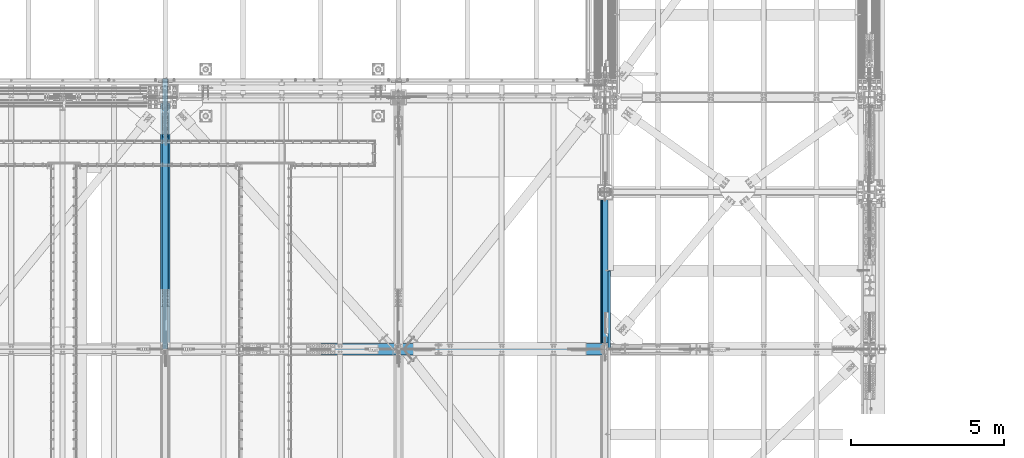
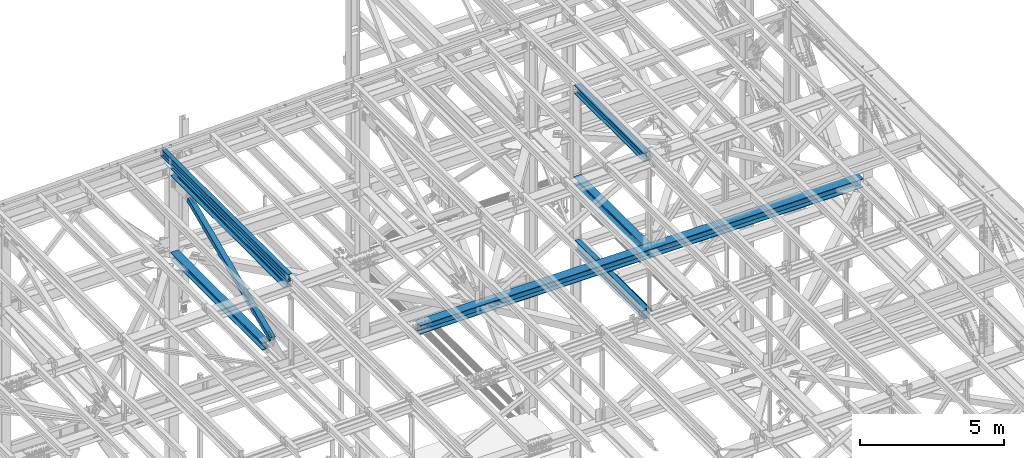
# One storey, part 1926 of 3843: 8 beams, 1 member, 9 elements without a shape of their own.
"""IFC2X3 building model written with IfcOpenShell, lengths in millimetres."""

from ifc_helpers import new_model, si_unit, frame, origin_with_axes, place, context, subcontext, project, spatial, faceted_brep, material, type_object, element, aggregate, save


model = new_model("IFC2X3")

# Units and contexts
model_context = context("Model", 3, precision=1e-05, world=origin_with_axes())
body_context = subcontext(model_context, "Body", "Model", "MODEL_VIEW")
ifc_project = project(units=[si_unit("LENGTHUNIT", "METRE", prefix="MILLI"), si_unit("AREAUNIT", "SQUARE_METRE"), si_unit("VOLUMEUNIT", "CUBIC_METRE"), si_unit("MASSUNIT", "GRAM", prefix="KILO"), si_unit("TIMEUNIT", "SECOND"), si_unit("PLANEANGLEUNIT", "RADIAN"), si_unit("SOLIDANGLEUNIT", "STERADIAN"), si_unit("THERMODYNAMICTEMPERATUREUNIT", "DEGREE_CELSIUS"), si_unit("LUMINOUSINTENSITYUNIT", "LUMEN")], contexts=[model_context])

# Site, building, storey
site_placement = place(None, origin_with_axes())
site = spatial("IfcSite", under=ifc_project, at=site_placement, CompositionType="ELEMENT")
building_placement = place(site_placement, origin_with_axes())
building = spatial("IfcBuilding", under=site, at=building_placement, Name="Undefined", CompositionType="ELEMENT")
storey_placement = place(building_placement, origin_with_axes())
storey = spatial("IfcBuildingStorey", under=building, at=storey_placement, Name="Undefined", CompositionType="ELEMENT", Elevation=0.0)

# Assembly, beam
assembly_1_placement = place(storey_placement, origin_with_axes())
assembly_1 = element("IfcElementAssembly", 1, at=assembly_1_placement, inside=storey, Name="BEAM", AssemblyPlace="NOTDEFINED", PredefinedType="RIGID_FRAME")
ifc_material_1 = material(Name="STEEL/A992")
beam_type_1 = type_object("IfcBeamType", Name="W12X26", PredefinedType="NOTDEFINED")
beam_1_placement = place(assembly_1_placement, frame((62633.1092623524, 83985.3212537026, 46137.8441766796), z_axis=(-0.0211520984080562, 0.00142216699976416, 0.999775257832459), x_axis=(0.0, 0.999998988266278, -0.00142248600037892)))
beam_1 = element("IfcBeam", 2, at=beam_1_placement, type_object=beam_type_1, material=ifc_material_1, Name="BEAM", ObjectType="W12X26", context=body_context, shape_type="Brep", body=[
    faceted_brep([(12.7024967079196, 82.5500000003085, -155.575000000172), (12.6889505463769, 82.5500000002867, -146.050000000156), (8839.20894275262, 82.5499999999811, -146.049999986019), (8839.20894275268, 82.5500000000102, -155.574999986035), (12.686562263887, 3.17500000043219, -146.050000000236), (8839.20894275226, 3.1750000001266, -146.049999986106), (12.2711466436303, 3.1749999995809, 146.050000000294), (8839.20894275064, 3.17499999927531, 146.050000014417), (12.2735349261202, 82.5499999994281, 146.050000000381), (8839.20894275102, 82.5499999991225, 146.050000014511), (12.2599887646065, 82.5499999994063, 155.57500000039), (8839.20894275096, 82.5499999991007, 155.575000014534), (12.2550211370108, -82.5500000002867, 155.575000000208), (8839.20894275019, -82.550000000585, 155.575000014338), (12.268567298539, -82.5500000002503, 146.050000000192), (8839.20894275024, -82.5500000005559, 146.050000014322), (12.2709555810434, -3.17500000040309, 146.050000000272), (8839.20894275061, -3.17500000070868, 146.050000014409), (12.686371201271, -3.1749999995518, -146.050000000243), (8839.20894275223, -3.17499999985012, -146.049999986106), (12.6839829187811, -82.5499999994063, -146.050000000345), (8839.20894275187, -82.5499999997046, -146.0499999862), (12.6975290803239, -82.5499999993772, -155.575000000354), (8839.20894275189, -82.5499999996828, -155.574999986224)], [[[0, 1, 2, 3]], [[1, 4, 5, 2]], [[4, 6, 7, 5]], [[6, 8, 9, 7]], [[8, 10, 11, 9]], [[10, 12, 13, 11]], [[12, 14, 15, 13]], [[14, 16, 17, 15]], [[16, 18, 19, 17]], [[18, 20, 21, 19]], [[20, 22, 23, 21]], [[22, 0, 3, 23]], [[5, 7, 9, 11, 13, 15, 17, 19, 21, 23, 3, 2]], [[22, 20, 18, 16, 14, 12, 10, 8, 6, 4, 1, 0]]]),
])
aggregate(assembly_1, [beam_1])

assembly_2_placement = place(storey_placement, origin_with_axes())
assembly_2 = element("IfcElementAssembly", 3, at=assembly_2_placement, inside=storey, Name="BENT_PLATE", AssemblyPlace="NOTDEFINED", PredefinedType="RIGID_FRAME")
ifc_material_2 = material(Name="STEEL/A36")
beam_type_2 = type_object("IfcBeamType", PredefinedType="NOTDEFINED")
beam_2_placement = place(assembly_2_placement, frame((77179.4875000005, 85277.325, 39627.1749999995), z_axis=(0.0, 1.0, 0.0), x_axis=(-1.0, 0.0, 0.0)))
beam_2 = element("IfcBeam", 4, at=beam_2_placement, type_object=beam_type_2, material=ifc_material_2, Name="BENT_PLATE", context=body_context, shape_type="Brep", body=[
    faceted_brep([(73.0250000002416, -7.27595761418343e-12, 1273.17500000002), (69.8500000002678, 3.17500000000291, 1270.00000000003), (0.0, 3.17500000000291, 1270.00000000003), (0.0, -7.27595761418343e-12, 1273.175), (73.0250000004453, 73.0249999997468, 1273.175), (69.8500000003405, 73.0249999997541, 1270.00000000003), (76.200000000259, -3.17500000000291, -1273.175), (0.0, -3.17500000000291, -1273.175), (0.0, 3.17500000000291, -1273.175), (69.8500000002678, 3.17500000000291, -1273.175), (69.8500000003405, 73.0249999997541, -1273.175), (76.2000000003463, 73.0249999997395, -1273.175), (76.200000000259, -3.17500000000291, 1273.175), (76.2000000003463, 73.0249999997395, 1273.175), (0.0, -3.17500000000291, 1273.175)], [[[0, 1, 2, 3]], [[4, 5, 1, 0]], [[6, 7, 8, 9, 10, 11]], [[12, 6, 11, 13]], [[14, 7, 6, 12]], [[8, 7, 14, 3, 2]], [[9, 8, 2, 1]], [[10, 9, 1, 5]], [[13, 11, 10, 5, 4]], [[14, 12, 13, 4, 0, 3]]]),
])
aggregate(assembly_2, [beam_2])

assembly_3_placement = place(storey_placement, origin_with_axes())
assembly_3 = element("IfcElementAssembly", 5, at=assembly_3_placement, inside=storey, Name="BEAM", AssemblyPlace="NOTDEFINED", PredefinedType="RIGID_FRAME")
beam_type_3 = type_object("IfcBeamType", Name="W12X79", PredefinedType="NOTDEFINED")
beam_3_placement = place(assembly_3_placement, frame((62636.399999016, 85661.4999999939, 42256.5692801511), z_axis=(0.0, 0.001528912000329, 0.999998831213365), x_axis=(0.0, 0.999998831213365, -0.00152891200032518)))
beam_3 = element("IfcBeam", 6, at=beam_3_placement, type_object=beam_type_3, material=ifc_material_1, Name="BEAM", ObjectType="W12X79", context=body_context, shape_type="Brep", body=[
    faceted_brep([(6.34999999578577, -153.987500000003, -138.11249999961), (6.34999999578577, -153.987500000003, -157.162499999562), (6362.46714881413, -153.987500000003, -157.162499986967), (6362.46714881428, -153.987500000003, -138.112499986986), (6.34999999578577, -6.34999999999854, -138.11249999961), (6362.46714881428, -6.34999999999854, -138.112499986986), (6.34999999578577, -6.34999999999854, 138.112499999675), (6362.4671488163, -6.34999999999854, 138.112500012634), (6.34999999578577, -153.987500000003, 138.112499999675), (6362.4671488163, -153.987500000003, 138.112500012634), (6.34999999578577, -153.987500000003, 157.162499999627), (6362.46714881643, -153.987500000003, 157.162500012608), (6.34999999578577, 153.987500000003, 157.162499999627), (6362.46714881643, 153.987500000003, 157.162500012608), (6.34999999578577, 153.987500000003, 138.112499999675), (6362.4671488163, 153.987500000003, 138.112500012634), (6.34999999578577, 6.34999999999854, 138.112499999675), (6362.4671488163, 6.34999999999854, 138.112500012634), (6.34999999578577, 6.34999999999854, -138.11249999961), (6362.46714881428, 6.34999999999854, -138.112499986986), (6.34999999578577, 153.987500000003, -138.11249999961), (6362.46714881428, 153.987500000003, -138.112499986986), (6.34999999578577, 153.987500000003, -157.162499999562), (6362.46714881413, 153.987500000003, -157.162499986967)], [[[0, 1, 2, 3]], [[4, 0, 3, 5]], [[6, 4, 5, 7]], [[8, 6, 7, 9]], [[10, 8, 9, 11]], [[12, 10, 11, 13]], [[14, 12, 13, 15]], [[16, 14, 15, 17]], [[18, 16, 17, 19]], [[20, 18, 19, 21]], [[1, 0, 4, 6, 8, 10, 12, 14, 16, 18, 20, 22]], [[1, 22, 23, 2]], [[19, 17, 15, 13, 11, 9, 7, 5, 3, 2, 23, 21]], [[22, 20, 21, 23]]]),
])
aggregate(assembly_3, [beam_3])

assembly_4_placement = place(storey_placement, origin_with_axes())
assembly_4 = element("IfcElementAssembly", 7, at=assembly_4_placement, inside=storey, Name="BEAM", AssemblyPlace="NOTDEFINED", PredefinedType="RIGID_FRAME")
beam_type_4 = type_object("IfcBeamType", Name="W14X120", PredefinedType="NOTDEFINED")
beam_4_placement = place(assembly_4_placement, frame((67716.4, 83985.1, 42261.5850587552), z_axis=(-0.00048281500021403, 0.0, 0.999999883444831), x_axis=(0.999999883444831, 0.0, 0.000482815000217081)))
beam_4 = element("IfcBeam", 8, at=beam_4_placement, type_object=beam_type_4, material=ifc_material_1, Name="BEAM", ObjectType="W14X120", context=body_context, shape_type="Brep", body=[
    faceted_brep([(6.34999999732827, -185.737500000003, -184.1500000003), (6.35000000674336, -185.737500000003, -160.33750000099), (6.34999999732827, -7.14375000000291, -160.337500000271), (6.34999999732827, -7.14375000000291, 160.337500000249), (6.35000000639411, -185.737500000003, 160.337500001014), (6.34999999734282, -185.737500000003, 184.150000000292), (6.34999999734282, 185.737500000003, 184.150000000292), (6.35000000639411, 185.737500000003, 160.337500001014), (6.34999999732827, 7.14375000000291, 160.337500000249), (6.34999999732827, 7.14375000000291, -160.337500000271), (6.35000000674336, 185.737500000003, -160.33750000099), (6.34999999732827, 185.737500000003, -184.1500000003), (17732.2881540681, -185.737500000003, -184.150000045403), (17732.2996511016, -185.737500000003, -160.337500045367), (17732.299651277, -147.637402224384, -160.337499988658), (17732.2996511016, -7.14375000000291, -160.337500045367), (17732.4544778199, -7.14375000000291, 160.337499955145), (17732.4544776769, -147.637402224384, 160.337500011701), (17732.4544778199, -185.737500000003, 160.337499955145), (17732.4659748534, -185.737500000003, 184.149999955182), (17732.4659746868, -147.637402224384, 184.15000001173), (17732.4659746868, 147.637584881566, 184.15000001173), (17732.4659748534, 185.737500000003, 184.149999955182), (17732.4544778199, 185.737500000003, 160.337499955145), (17732.4544776769, 147.637584881566, 160.337500011701), (17732.4544778199, 7.14375000000291, 160.337499955145), (17732.4356630119, 7.14375000000291, 121.368524726146), (17732.3184451861, 7.14375000000291, -121.411446977356), (17732.2996511016, 7.14375000000291, -160.337500045367), (17732.299651277, 147.637584881566, -160.337499988658), (17732.2996511016, 185.737500000003, -160.337500045367), (17732.2881540681, 185.737500000003, -184.150000045403), (17732.2881542671, -147.637402224384, -184.149999988687), (17732.2881542671, 147.637584881566, -184.149999988687)], [[[0, 1, 2, 3, 4, 5, 6, 7, 8, 9, 10, 11]], [[1, 0, 12, 13]], [[2, 1, 13, 14, 15]], [[3, 2, 15, 16]], [[4, 3, 16, 17, 18]], [[5, 4, 18, 19]], [[6, 5, 19, 20, 21, 22]], [[7, 6, 22, 23]], [[8, 7, 23, 24, 25]], [[9, 8, 25, 26, 27, 28]], [[10, 9, 28, 29, 30]], [[11, 10, 30, 31]], [[29, 28, 27, 26, 25, 24, 23, 22, 21, 20, 19, 18, 17, 16, 15, 14, 13, 12, 32, 33, 31, 30]], [[0, 11, 31, 33, 32, 12]]]),
])
aggregate(assembly_4, [beam_4])

# Assembly, member
assembly_5_placement = place(storey_placement, origin_with_axes())
assembly_5 = element("IfcElementAssembly", 9, at=assembly_5_placement, inside=storey, AssemblyPlace="NOTDEFINED", PredefinedType="RIGID_FRAME")
ifc_material_3 = material()
member_type = type_object("IfcMemberType", Name="HSS8X8X1/2", PredefinedType="NOTDEFINED")
member_placement = place(assembly_5_placement, frame((62636.3999983394, 83985.0999999778, 42259.1323511586), z_axis=(1.0, 0.0, 0.0), x_axis=(0.0, 0.919173162811554, 0.393853648919246)))
member = element("IfcMember", 10, at=member_placement, type_object=member_type, material=ifc_material_3, ObjectType="HSS8X8X1/2", context=body_context, shape_type="Brep", body=[
    faceted_brep([(1364.28375243548, -101.599999994409, 17.4625000000015), (1364.28375243559, -88.8999999944626, 17.4625000000015), (1616.69625280701, -88.8999999935022, 17.4625000000015), (1616.69625280688, -101.599999993456, 17.4625000000015), (1623.37886209866, -88.8999999934804, 16.1332463655199), (1623.37886209856, -101.599999993434, 16.1332463655199), (1629.04410470369, -88.8999999934658, 12.3478522782025), (1629.04410470356, -101.599999993405, 12.3478522782025), (1632.82949879098, -88.899999993444, 6.68260967316746), (1632.82949879084, -101.59999999339, 6.68260967316746), (1616.69625280688, -101.599999993456, -17.4625000000015), (1616.69625280701, -88.8999999935022, -17.4625000000015), (1364.28375243559, -88.8999999944626, -17.4625000000015), (1364.28375243548, -101.599999994409, -17.4625000000015), (1623.37886209856, -101.599999993434, -16.1332463655199), (1623.37886209866, -88.8999999934804, -16.1332463655199), (1629.04410470356, -101.599999993405, -12.3478522782025), (1629.04410470369, -88.8999999934658, -12.3478522782025), (1632.82949879084, -101.59999999339, -6.68260967316746), (1632.82949879098, -88.899999993444, -6.68260967316746), (1634.15875242533, -101.599999993383, 3.81471181754023e-07), (1634.15875242547, -88.899999993444, 3.81471181754023e-07), (1364.28375243676, 88.9000000047981, 17.4625000000015), (1364.28375243685, 101.600000004752, 17.4625000000015), (1616.69625280882, 101.600000005705, 17.4625000000015), (1616.69625280872, 88.9000000057513, 17.4625000000015), (1623.37886210049, 101.600000005719, 16.1332463655199), (1623.37886210038, 88.9000000057804, 16.1332463655199), (1629.04410470549, 101.600000005748, 12.3478522782025), (1629.04410470539, 88.9000000057949, 12.3478522782025), (1632.82949879281, 101.600000005763, 6.68260967316746), (1632.82949879269, 88.9000000058168, 6.68260967316746), (1616.69625280872, 88.9000000057513, -17.4625000000015), (1616.69625280882, 101.600000005705, -17.4625000000015), (1364.28375243685, 101.600000004752, -17.4625000000015), (1364.28375243676, 88.9000000047981, -17.4625000000015), (1623.37886210038, 88.9000000057804, -16.1332463655199), (1623.37886210049, 101.600000005719, -16.1332463655199), (1629.04410470539, 88.9000000057949, -12.3478522782025), (1629.04410470549, 101.600000005748, -12.3478522782025), (1632.82949879269, 88.9000000058168, -6.68260967316746), (1632.82949879281, 101.600000005763, -6.68260967316746), (1634.15875242716, 88.900000005824, 3.81471181754023e-07), (1634.15875242728, 101.600000005777, 3.81471181754023e-07), (1364.28375243559, -88.8999999944626, 88.9000000000015), (1364.28375243676, 88.9000000047981, 88.9000000000015), (7586.19055475817, 88.9000000283941, 88.9000000000015), (7586.19055475698, -88.8999999708667, 88.9000000000015), (1364.28375243685, 101.600000004752, 101.599999999999), (7586.19055475826, 101.60000002834, 101.599999999999), (7586.19055475826, 101.60000002834, 41.2750000000015), (7333.77805439882, 101.600000027387, 41.2750000000015), (7327.09544510716, 101.600000027358, 39.9457463655199), (7321.43020250213, 101.600000027336, 36.1603522782025), (7317.64480841484, 101.600000027322, 30.4951096731675), (7316.31555478036, 101.600000027314, 23.8125003814712), (7317.64480841484, 101.600000027322, 17.1298903268325), (7321.43020250213, 101.600000027336, 11.4646477217975), (7327.09544510716, 101.600000027358, 7.67925363448012), (7333.77805439882, 101.600000027387, 6.34999999999854), (7586.19055475826, 101.60000002834, 6.34999999999854), (7586.19055475826, 101.60000002834, -101.599999999999), (1364.28375243685, 101.600000004752, -101.599999999999), (7586.19055475817, 88.9000000283941, 41.2750000000015), (7333.7780543987, 88.9000000274264, 41.2750000000015), (7327.09544510703, 88.9000000274118, 39.9457463655199), (7321.43020250202, 88.9000000273973, 36.1603522782025), (7317.64480841473, 88.9000000273754, 30.4951096731675), (7316.31555478023, 88.9000000273754, 23.8125003814712), (7317.64480841473, 88.9000000273754, 17.1298903268325), (7321.43020250202, 88.9000000273973, 11.4646477217975), (7327.09544510703, 88.9000000274118, 7.67925363448012), (7333.7780543987, 88.9000000274264, 6.34999999999854), (7586.19055475817, 88.9000000283941, 6.34999999999854), (1364.28375243676, 88.9000000047981, -88.9000000000015), (1364.28375243559, -88.8999999944626, -88.9000000000015), (7586.19055475698, -88.8999999708667, -88.9000000000015), (7586.19055475817, 88.9000000283941, -88.9000000000015), (7327.09544510521, -101.599999971795, 39.9457463655199), (7327.09544510533, -88.8999999718562, 39.9457463655199), (7333.77805439699, -88.8999999718271, 41.2750000000015), (7333.77805439687, -101.599999971773, 41.2750000000015), (7321.43020250018, -101.599999971817, 36.1603522782025), (7321.43020250033, -88.8999999718708, 36.1603522782025), (7317.64480841289, -101.599999971839, 30.4951096731675), (7317.64480841301, -88.8999999718853, 30.4951096731675), (7316.31555477841, -101.599999971846, 23.8125003814712), (7316.31555477851, -88.8999999718926, 23.8125003814712), (7317.64480841289, -101.599999971839, 17.1298903268325), (7317.64480841301, -88.8999999718853, 17.1298903268325), (7321.43020250018, -101.599999971817, 11.4646477217975), (7321.43020250033, -88.8999999718708, 11.4646477217975), (7327.09544510521, -101.599999971795, 7.67925363448012), (7327.09544510533, -88.8999999718562, 7.67925363448012), (7333.77805439687, -101.599999971773, 6.34999999999854), (7333.77805439699, -88.8999999718271, 6.34999999999854), (7586.1905547569, -101.599999970813, 6.34999999999854), (7586.19055475698, -88.8999999708667, 6.34999999999854), (7586.1905547569, -101.599999970813, -101.599999999999), (1364.28375243548, -101.599999994409, -101.599999999999), (7586.19055475698, -88.8999999708667, 41.2750000000015), (7586.1905547569, -101.599999970813, 41.2750000000015), (7586.1905547569, -101.599999970813, 101.599999999999), (1364.28375243548, -101.599999994409, 101.599999999999)], [[[0, 1, 2, 3]], [[3, 2, 4, 5]], [[5, 4, 6, 7]], [[7, 6, 8, 9]], [[10, 11, 12, 13]], [[14, 15, 11, 10]], [[16, 17, 15, 14]], [[18, 19, 17, 16]], [[20, 21, 19, 18]], [[9, 8, 21, 20]], [[22, 23, 24, 25]], [[25, 24, 26, 27]], [[27, 26, 28, 29]], [[29, 28, 30, 31]], [[32, 33, 34, 35]], [[36, 37, 33, 32]], [[38, 39, 37, 36]], [[40, 41, 39, 38]], [[42, 43, 41, 40]], [[31, 30, 43, 42]], [[44, 45, 46, 47]], [[28, 26, 24, 23, 48, 49, 50, 51, 52, 53, 54, 55, 56, 57, 58, 59, 60, 61, 62, 34, 33, 37, 39, 41, 43, 30]], [[63, 64, 51, 50]], [[65, 52, 51, 64]], [[66, 53, 52, 65]], [[67, 54, 53, 66]], [[68, 55, 54, 67]], [[69, 56, 55, 68]], [[70, 57, 56, 69]], [[71, 58, 57, 70]], [[72, 59, 58, 71]], [[73, 60, 59, 72]], [[74, 75, 76, 77]], [[78, 79, 80, 81]], [[82, 83, 79, 78]], [[84, 85, 83, 82]], [[86, 87, 85, 84]], [[88, 89, 87, 86]], [[90, 91, 89, 88]], [[92, 93, 91, 90]], [[94, 95, 93, 92]], [[96, 97, 95, 94]], [[98, 61, 60, 73, 77, 76, 97, 96]], [[99, 62, 61, 98]], [[75, 74, 35, 34, 62, 99, 13, 12]], [[6, 4, 2, 1, 44, 47, 100, 80, 79, 83, 85, 87, 89, 91, 93, 95, 97, 76, 75, 12, 11, 15, 17, 19, 21, 8]], [[101, 81, 80, 100]], [[47, 46, 63, 50, 49, 102, 101, 100]], [[48, 103, 102, 49]], [[16, 14, 10, 13, 99, 98, 96, 94, 92, 90, 88, 86, 84, 82, 78, 81, 101, 102, 103, 0, 3, 5, 7, 9, 20, 18]], [[103, 48, 23, 22, 45, 44, 1, 0]], [[38, 36, 32, 35, 74, 77, 73, 72, 71, 70, 69, 68, 67, 66, 65, 64, 63, 46, 45, 22, 25, 27, 29, 31, 42, 40]]]),
])
aggregate(assembly_5, [member])

# Assembly, beam
assembly_6_placement = place(storey_placement, origin_with_axes())
assembly_6 = element("IfcElementAssembly", 11, at=assembly_6_placement, inside=storey, Name="BEAM", AssemblyPlace="NOTDEFINED", PredefinedType="RIGID_FRAME")
beam_type_5 = type_object("IfcBeamType", Name="W14X68", PredefinedType="NOTDEFINED")
beam_5_placement = place(assembly_6_placement, frame((77012.8, 83985.1, 46096.5034722281), z_axis=(0.0, 0.00380209400005697, 0.999992772014486), x_axis=(0.0, 0.999992772014486, -0.00380209400005526)))
beam_5 = element("IfcBeam", 12, at=beam_5_placement, type_object=beam_type_5, material=ifc_material_1, Name="BEAM", ObjectType="W14X68", context=body_context, shape_type="Brep", body=[
    faceted_brep([(213.330124371947, -127.0, -158.749999999149), (213.402554786167, -127.0, -177.799999999123), (5017.21227670657, -127.0, -177.799999986091), (5017.13984629234, -127.0, -158.749999986125), (213.330124371947, -5.55624999999418, -158.749999999149), (5017.13984629234, -5.55624999999418, -158.749999986125), (212.12295080148, -5.55624999999418, 158.750000000298), (5015.93267272189, -5.55624999999418, 158.75000001333), (212.12295080148, -127.0, 158.750000000298), (5015.93267272189, -127.0, 158.75000001333), (212.050520387245, -127.0, 177.800000000265), (5015.86024230765, -127.0, 177.800000013296), (212.050520387245, 127.0, 177.800000000265), (5015.86024230765, 127.0, 177.800000013296), (212.12295080148, 127.0, 158.750000000298), (5015.93267272189, 127.0, 158.75000001333), (212.12295080148, 5.55624999999418, 158.750000000298), (5015.93267272189, 5.55624999999418, 158.75000001333), (213.330124371947, 5.55624999999418, -158.749999999149), (5016.00164596931, 5.55624999999418, 140.609273114424), (5016.92471835065, 5.55624999999418, -102.168972073261), (5017.13984629234, 5.55624999999418, -158.749999986125), (213.330124371947, 127.0, -158.749999999149), (5017.13984629234, 127.0, -158.749999986125), (213.402554786167, 127.0, -177.799999999123), (5017.21227670657, 127.0, -177.799999986091)], [[[0, 1, 2, 3]], [[4, 0, 3, 5]], [[6, 4, 5, 7]], [[8, 6, 7, 9]], [[10, 8, 9, 11]], [[12, 10, 11, 13]], [[14, 12, 13, 15]], [[16, 14, 15, 17]], [[18, 16, 17, 19, 20, 21]], [[22, 18, 21, 23]], [[1, 0, 4, 6, 8, 10, 12, 14, 16, 18, 22, 24]], [[1, 24, 25, 2]], [[21, 20, 19, 17, 15, 13, 11, 9, 7, 5, 3, 2, 25, 23]], [[24, 22, 23, 25]]]),
])
aggregate(assembly_6, [beam_5])

assembly_7_placement = place(storey_placement, origin_with_axes())
assembly_7 = element("IfcElementAssembly", 13, at=assembly_7_placement, inside=storey, Name="BEAM", AssemblyPlace="NOTDEFINED", PredefinedType="RIGID_FRAME")
beam_type_6 = type_object("IfcBeamType", Name="W12X65", PredefinedType="NOTDEFINED")
beam_6_placement = place(assembly_7_placement, frame((62636.4, 83985.1, 45785.4080578587), z_axis=(0.0, 0.0, 1.0), x_axis=(0.0, 1.0, 0.0)))
beam_6 = element("IfcBeam", 14, at=beam_6_placement, type_object=beam_type_6, material=ifc_material_1, Name="BEAM", ObjectType="W12X65", context=body_context, shape_type="Brep", body=[
    faceted_brep([(212.725000000006, -152.399999999994, -138.112500000003), (212.725000000006, -152.399999999994, -153.987500000003), (8039.09999999887, -152.399999999994, -153.987500000003), (8039.09999999887, -152.399999999994, -138.112500000003), (212.725000000006, -4.76249999999709, -138.112500000003), (8039.09999999887, -4.76249999999709, -138.112500000003), (212.725000000006, -4.76249999999709, 138.112500000003), (8039.09999999887, -4.76249999999709, 138.112500000003), (212.725000000006, -152.399999999994, 138.112500000003), (8039.09999999887, -152.399999999994, 138.112500000003), (212.725000000006, -152.399999999994, 153.987500000003), (8039.09999999887, -152.399999999994, 153.987500000003), (212.725000000006, 152.399999999994, 153.987500000003), (8039.09999999887, 152.399999999994, 153.987500000003), (212.725000000006, 152.399999999994, 138.112500000003), (8039.09999999887, 152.399999999994, 138.112500000003), (212.725000000006, 4.76249999999709, 138.112500000003), (8039.09999999887, 4.76249999999709, 138.112500000003), (212.725000000006, 4.76249999999709, -138.112500000003), (8039.09999999887, 4.76249999999709, -138.112500000003), (212.725000000006, 152.399999999994, -138.112500000003), (8039.09999999887, 152.399999999994, -138.112500000003), (212.725000000006, 152.399999999994, -153.987500000003), (8039.09999999887, 152.399999999994, -153.987500000003)], [[[0, 1, 2, 3]], [[4, 0, 3, 5]], [[6, 4, 5, 7]], [[8, 6, 7, 9]], [[10, 8, 9, 11]], [[12, 10, 11, 13]], [[14, 12, 13, 15]], [[16, 14, 15, 17]], [[18, 16, 17, 19]], [[20, 18, 19, 21]], [[1, 0, 4, 6, 8, 10, 12, 14, 16, 18, 20, 22]], [[1, 22, 23, 2]], [[19, 17, 15, 13, 11, 9, 7, 5, 3, 2, 23, 21]], [[22, 20, 21, 23]]]),
])
aggregate(assembly_7, [beam_6])

assembly_8_placement = place(storey_placement, origin_with_axes())
assembly_8 = element("IfcElementAssembly", 15, at=assembly_8_placement, inside=storey, Name="BEAM", AssemblyPlace="NOTDEFINED", PredefinedType="RIGID_FRAME")
beam_7_placement = place(assembly_8_placement, frame((77012.8, 83985.1, 42266.0734914176), z_axis=(0.0, 0.00380512800179713, 0.99999276047424), x_axis=(0.0, 0.99999276047424, -0.00380512800180433)))
beam_7 = element("IfcBeam", 16, at=beam_7_placement, type_object=beam_type_6, material=ifc_material_1, Name="BEAM", ObjectType="W12X65", context=body_context, shape_type="Brep", body=[
    faceted_brep([(199.024882996397, -152.399999999994, -153.987499999261), (198.964476152047, -152.399999999994, -138.112499999268), (198.964476152047, -4.76249999999709, -138.112499999268), (197.913397060416, -4.76249999999709, 138.11250000041), (197.913397060416, -152.399999999994, 138.11250000041), (197.852990216081, -152.399999999994, 153.987500000389), (197.852990216081, 152.399999999994, 153.987500000389), (197.913397060416, 152.399999999994, 138.11250000041), (197.913397060416, 4.76249999999709, 138.11250000041), (198.964476152047, 4.76249999999709, -138.112499999268), (198.964476152047, 152.399999999994, -138.112499999268), (199.024882996397, 152.399999999994, -153.987499999261), (5017.12226451343, -152.399999999994, -153.987499985298), (5017.06185766908, -152.399999999994, -138.11249998532), (5017.06185766908, -146.050000000003, -138.11249998532), (5017.06185766908, -4.76249999999709, -138.11249998532), (5016.01077857746, -4.76249999999709, 138.112500014366), (5016.01077857746, -146.050000000003, 138.112500014366), (5016.01077857746, -152.399999999994, 138.112500014366), (5015.95037173311, -152.399999999994, 153.987500014344), (5015.95037173311, -146.050000000003, 153.987500014344), (5015.95037173311, 146.050000000003, 153.987500014344), (5015.95037173311, 152.399999999994, 153.987500014344), (5016.01077857746, 152.399999999994, 138.112500014366), (5016.01077857746, 146.050000000003, 138.112500014366), (5016.01077857746, 4.76249999999709, 138.112500014366), (5016.09271528738, 4.76249999999709, 116.579422360315), (5016.96819913805, 4.76249999999709, -113.498911969058), (5017.06185766908, 4.76249999999709, -138.11249998532), (5017.06185766908, 146.050000000003, -138.11249998532), (5017.06185766908, 152.399999999994, -138.11249998532), (5017.12226451343, 152.399999999994, -153.987499985298), (5017.12226451343, -146.050000000003, -153.987499985298), (5017.12226451343, 146.050000000003, -153.987499985298)], [[[0, 1, 2, 3, 4, 5, 6, 7, 8, 9, 10, 11]], [[1, 0, 12, 13]], [[2, 1, 13, 14, 15]], [[3, 2, 15, 16]], [[4, 3, 16, 17, 18]], [[5, 4, 18, 19]], [[6, 5, 19, 20, 21, 22]], [[7, 6, 22, 23]], [[8, 7, 23, 24, 25]], [[9, 8, 25, 26, 27, 28]], [[10, 9, 28, 29, 30]], [[11, 10, 30, 31]], [[29, 28, 27, 26, 25, 24, 23, 22, 21, 20, 19, 18, 17, 16, 15, 14, 13, 12, 32, 33, 31, 30]], [[0, 11, 31, 33, 32, 12]]]),
])
aggregate(assembly_8, [beam_7])

assembly_9_placement = place(storey_placement, origin_with_axes())
assembly_9 = element("IfcElementAssembly", 17, at=assembly_9_placement, inside=storey, Name="BEAM", AssemblyPlace="NOTDEFINED", PredefinedType="RIGID_FRAME")
beam_type_7 = type_object("IfcBeamType", Name="W16X57", PredefinedType="NOTDEFINED")
beam_8_placement = place(assembly_9_placement, frame((77012.8, 83985.1, 39476.3625), z_axis=(0.0, 0.0, 1.0), x_axis=(0.0, 1.0, 0.0)))
beam_8 = element("IfcBeam", 18, at=beam_8_placement, type_object=beam_type_7, material=ifc_material_1, Name="BEAM", ObjectType="W16X57", context=body_context, shape_type="Brep", body=[
    faceted_brep([(5016.5, -90.4875000000029, 190.5), (5016.5, -90.4875000000029, 207.962500000001), (208.756249999977, -90.4875000000029, 207.962500000001), (208.756249999977, -90.4875000000029, 190.5), (5016.5, 90.4875000000029, 207.962500000001), (208.756249999977, 90.4875000000029, 207.962500000001), (5016.5, 90.4875000000029, 190.5), (208.756249999977, 90.4875000000029, 190.5), (5016.5, 5.55624999999418, 190.5), (208.756249999977, 5.55624999999418, 190.5), (196.05625019077, -5.55624999999418, 106.362499984003), (196.05625019077, 5.55624999999418, 106.362499984003), (18.2562500000058, 5.55624999999418, 106.362499984003), (18.2562500000058, -5.55624999999418, 106.362499984003), (200.916329708809, -5.55624999999418, 107.329229906594), (200.916329708809, 5.55624999999418, 107.329229906594), (205.03650617697, -5.55624999999418, 110.082243807068), (205.03650617697, 5.55624999999418, 110.082243807068), (207.789520077451, -5.55624999999418, 114.202420275222), (207.789520077451, 5.55624999999418, 114.202420275222), (208.756250000035, -5.55624999999418, 119.062499793268), (208.756250000035, 5.55624999999418, 119.062499793268), (208.756249999977, -5.55624999999418, 190.5), (5016.5, -5.55624999999418, 190.5), (5016.5, 5.55624999999418, -190.5), (5016.5, -5.55624999999418, 170.602500000001), (5016.5, -5.55624999999418, -135.677499999998), (5016.5, -5.55624999999418, -190.5), (5016.5, -90.4875000000029, -190.5), (5016.5, -90.4875000000029, -207.962500000001), (5016.5, 90.4875000000029, -207.962500000001), (5016.5, 90.4875000000029, -190.5), (208.756249999977, -90.4875000000029, -190.5), (208.756249999977, -90.4875000000029, -207.962500000001), (208.756249999977, 90.4875000000029, -207.962500000001), (208.756249999977, 90.4875000000029, -190.5), (208.756249999977, 5.55624999999418, -190.5), (205.036506176912, 5.55624999999418, -160.882243823064), (200.916329708751, 5.55624999999418, -158.12922992259), (196.056250190712, 5.55624999999418, -157.162499999999), (18.2562499999767, 5.55624999999418, -157.162499999999), (208.756249999977, 5.55624999999418, -169.862499809264), (207.789520077393, 5.55624999999418, -165.002420291217), (18.2562499999767, -5.55624999999418, -136.9375), (18.2562499999767, -5.55624999999418, 93.6624999999985), (18.2562499999767, -5.55624999999418, -157.162499999999), (196.056250190712, -5.55624999999418, -157.162499999999), (200.916329708751, -5.55624999999418, -158.12922992259), (205.036506176912, -5.55624999999418, -160.882243823064), (207.789520077393, -5.55624999999418, -165.002420291217), (208.756249999977, -5.55624999999418, -169.862499809264), (208.756249999977, -5.55624999999418, -190.5)], [[[0, 1, 2, 3]], [[1, 4, 5, 2]], [[4, 6, 7, 5]], [[6, 8, 9, 7]], [[10, 11, 12, 13]], [[14, 15, 11, 10]], [[16, 17, 15, 14]], [[18, 19, 17, 16]], [[20, 21, 19, 18]], [[2, 5, 7, 9, 21, 20, 22, 3]], [[23, 0, 3, 22]], [[24, 8, 6, 4, 1, 0, 23, 25, 26, 27, 28, 29, 30, 31]], [[29, 28, 32, 33]], [[30, 29, 33, 34]], [[31, 30, 34, 35]], [[24, 31, 35, 36]], [[37, 38, 39, 40, 12, 11, 15, 17, 19, 21, 9, 8, 24, 36, 41, 42]], [[43, 44, 13, 12, 40, 45]], [[27, 26, 25, 23, 22, 20, 18, 16, 14, 10, 13, 44, 43, 45, 46, 47, 48, 49, 50, 51]], [[28, 27, 51, 32]], [[50, 41, 36, 35, 34, 33, 32, 51]], [[49, 42, 41, 50]], [[48, 37, 42, 49]], [[47, 38, 37, 48]], [[46, 39, 38, 47]], [[45, 40, 39, 46]]]),
])
aggregate(assembly_9, [beam_8])

save(model, "model.ifc")
